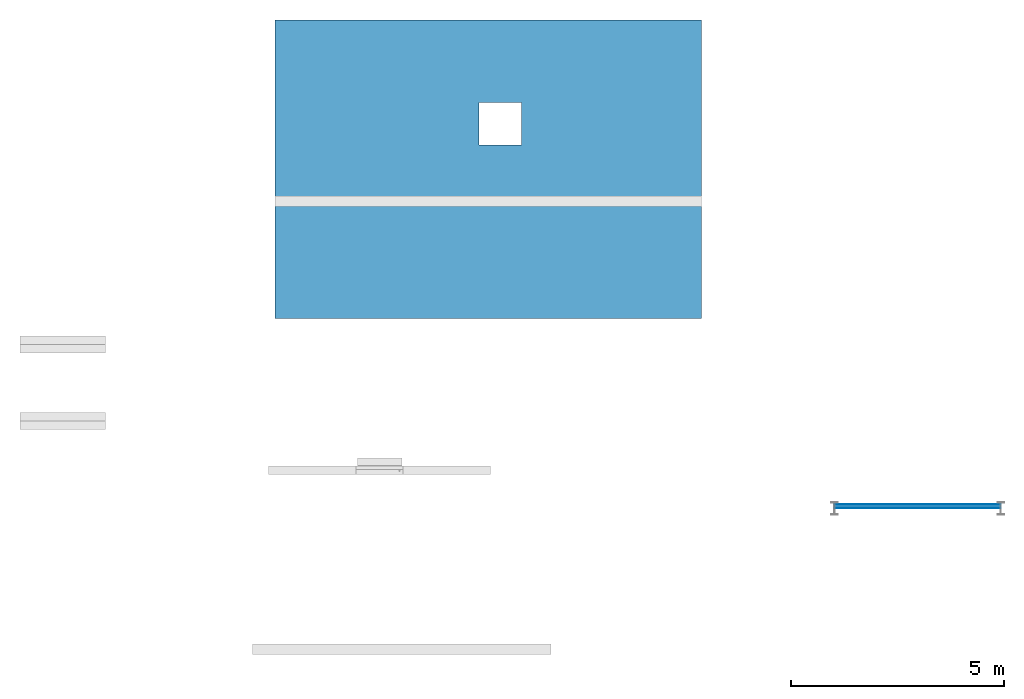
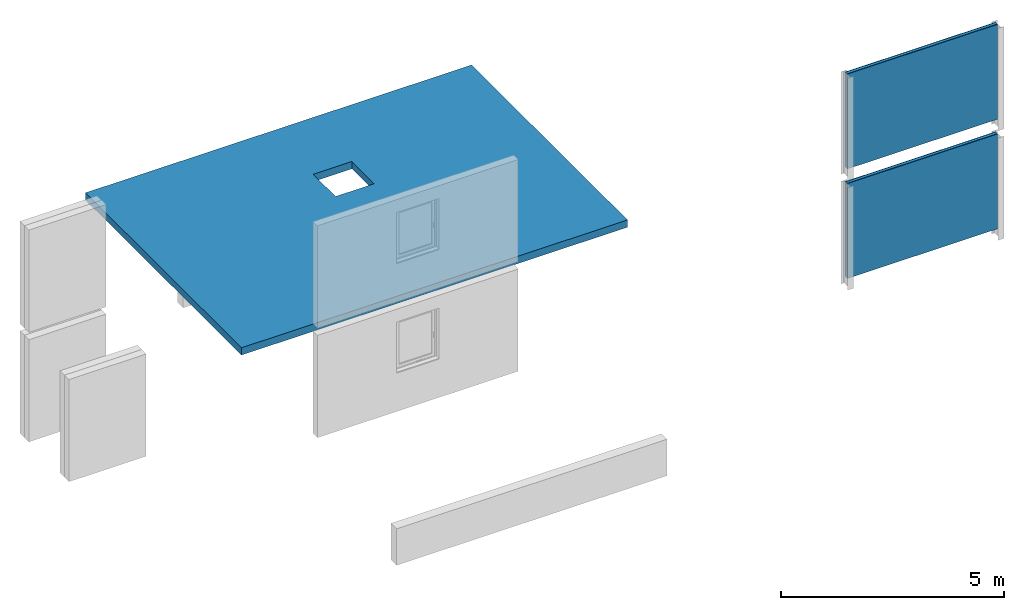
# Not in any storey, part 2 of 3: 7 building element parts, 3 elements without a shape of their own.
"""IFC4 model written with IfcOpenShell, lengths in metres."""

from ifc_helpers import new_model, entity, si_unit, converted_unit, derived_unit, direction, frame, origin, place, context, subcontext, project, spatial, indexed_curve, outline, extrude, material, type_object, element, aggregate, save


model = new_model("IFC4")

# Units and contexts
model_context = context("Model", 3, precision=1e-05, world=origin(), true_north=direction((6.123031769111886e-17, 1.0)))
body_context = subcontext(model_context, "Body", "Model", "MODEL_VIEW")
ifc_project = project(units=[si_unit("LENGTHUNIT", "METRE"), si_unit("AREAUNIT", "SQUARE_METRE"), si_unit("VOLUMEUNIT", "CUBIC_METRE"), converted_unit("PLANEANGLEUNIT", "DEGREE", entity("IfcRatioMeasure", 0.017453292519943278), si_unit("PLANEANGLEUNIT", "RADIAN"), dimensions=[0, 0, 0, 0, 0, 0, 0]), si_unit("MASSUNIT", "GRAM", prefix="KILO"), derived_unit("MASSDENSITYUNIT", [(si_unit("MASSUNIT", "GRAM", prefix="KILO"), 1), (si_unit("LENGTHUNIT", "METRE"), -3)]), derived_unit("IONCONCENTRATIONUNIT", [(si_unit("MASSUNIT", "GRAM", prefix="KILO"), 1), (si_unit("LENGTHUNIT", "METRE"), -3)]), derived_unit("MOMENTOFINERTIAUNIT", [(si_unit("LENGTHUNIT", "METRE"), 4)]), si_unit("TIMEUNIT", "SECOND"), si_unit("FREQUENCYUNIT", "HERTZ"), si_unit("THERMODYNAMICTEMPERATUREUNIT", "DEGREE_CELSIUS"), derived_unit("THERMALTRANSMITTANCEUNIT", [(si_unit("MASSUNIT", "GRAM", prefix="KILO"), 1), (si_unit("THERMODYNAMICTEMPERATUREUNIT", "KELVIN"), -1), (si_unit("TIMEUNIT", "SECOND"), -3)]), derived_unit("THERMALCONDUCTANCEUNIT", [(si_unit("MASSUNIT", "GRAM", prefix="KILO"), 1), (si_unit("THERMODYNAMICTEMPERATUREUNIT", "KELVIN"), -1), (si_unit("TIMEUNIT", "SECOND"), -3), (si_unit("LENGTHUNIT", "METRE"), 1)]), derived_unit("VOLUMETRICFLOWRATEUNIT", [(si_unit("LENGTHUNIT", "METRE"), 3), (si_unit("TIMEUNIT", "SECOND"), -1)]), derived_unit("MASSFLOWRATEUNIT", [(si_unit("MASSUNIT", "GRAM", prefix="KILO"), 1), (si_unit("TIMEUNIT", "SECOND"), -1)]), derived_unit("ROTATIONALFREQUENCYUNIT", [(si_unit("TIMEUNIT", "SECOND"), -1)]), si_unit("ELECTRICCURRENTUNIT", "AMPERE"), si_unit("ELECTRICVOLTAGEUNIT", "VOLT"), si_unit("POWERUNIT", "WATT"), si_unit("FORCEUNIT", "NEWTON", prefix="KILO"), si_unit("ILLUMINANCEUNIT", "LUX"), si_unit("LUMINOUSFLUXUNIT", "LUMEN"), si_unit("LUMINOUSINTENSITYUNIT", "CANDELA"), derived_unit("USERDEFINED", [(si_unit("MASSUNIT", "GRAM", prefix="KILO"), -1), (si_unit("LENGTHUNIT", "METRE"), -2), (si_unit("TIMEUNIT", "SECOND"), 3), (si_unit("LUMINOUSFLUXUNIT", "LUMEN"), 1)]), derived_unit("USERDEFINED", [(si_unit("MASSUNIT", "GRAM", prefix="KILO"), 1), (si_unit("TIMEUNIT", "SECOND"), -3), (si_unit("LENGTHUNIT", "METRE"), 3), (si_unit("ELECTRICCURRENTUNIT", "AMPERE"), -2)]), derived_unit("SOUNDPOWERUNIT", [(si_unit("MASSUNIT", "GRAM", prefix="KILO"), 1), (si_unit("TIMEUNIT", "SECOND"), -3), (si_unit("LENGTHUNIT", "METRE"), 2)]), derived_unit("SOUNDPRESSUREUNIT", [(si_unit("MASSUNIT", "GRAM", prefix="KILO"), 1), (si_unit("LENGTHUNIT", "METRE"), -1), (si_unit("TIMEUNIT", "SECOND"), -2)]), derived_unit("LINEARVELOCITYUNIT", [(si_unit("LENGTHUNIT", "METRE"), 1), (si_unit("TIMEUNIT", "SECOND"), -1)]), si_unit("PRESSUREUNIT", "PASCAL"), derived_unit("USERDEFINED", [(si_unit("MASSUNIT", "GRAM", prefix="KILO"), 1), (si_unit("LENGTHUNIT", "METRE"), -2), (si_unit("TIMEUNIT", "SECOND"), -2)]), derived_unit("LINEARFORCEUNIT", [(si_unit("MASSUNIT", "GRAM", prefix="KILO"), 1), (si_unit("TIMEUNIT", "SECOND"), -2)]), derived_unit("PLANARFORCEUNIT", [(si_unit("MASSUNIT", "GRAM", prefix="KILO"), 1), (si_unit("LENGTHUNIT", "METRE"), -1), (si_unit("TIMEUNIT", "SECOND"), -2)]), derived_unit("SPECIFICHEATCAPACITYUNIT", [(si_unit("THERMODYNAMICTEMPERATUREUNIT", "KELVIN"), -1), (si_unit("LENGTHUNIT", "METRE"), 2), (si_unit("TIMEUNIT", "SECOND"), -2)]), derived_unit("HEATINGVALUEUNIT", [(si_unit("LENGTHUNIT", "METRE"), 2), (si_unit("TIMEUNIT", "SECOND"), -2)]), derived_unit("VAPORPERMEABILITYUNIT", [(si_unit("LENGTHUNIT", "METRE"), -1), (si_unit("TIMEUNIT", "SECOND"), 1)]), derived_unit("DYNAMICVISCOSITYUNIT", [(si_unit("MASSUNIT", "GRAM", prefix="KILO"), 1), (si_unit("TIMEUNIT", "SECOND"), -1), (si_unit("LENGTHUNIT", "METRE"), -1)]), derived_unit("THERMALEXPANSIONCOEFFICIENTUNIT", [(si_unit("THERMODYNAMICTEMPERATUREUNIT", "KELVIN"), -1)]), derived_unit("MODULUSOFELASTICITYUNIT", [(si_unit("MASSUNIT", "GRAM", prefix="KILO"), 1), (si_unit("LENGTHUNIT", "METRE"), -1), (si_unit("TIMEUNIT", "SECOND"), -2)]), derived_unit("ISOTHERMALMOISTURECAPACITYUNIT", [(si_unit("LENGTHUNIT", "METRE"), 3), (si_unit("MASSUNIT", "GRAM", prefix="KILO"), -1)]), derived_unit("MOISTUREDIFFUSIVITYUNIT", [(si_unit("TIMEUNIT", "SECOND"), -1), (si_unit("LENGTHUNIT", "METRE"), 2)])], contexts=[model_context])

# Site
site_placement = place(None, origin())
site = spatial("IfcSite", under=ifc_project, at=site_placement, CompositionType="ELEMENT")

# Slab, building element part
slab_type = type_object("IfcSlabType", Name="Geschossdecke:STB 200", PredefinedType="NOTDEFINED")
slab_placement = place(site_placement, origin())
slab = element("IfcSlab", 1, at=slab_placement, inside=site, type_object=slab_type, Name="Geschossdecke:STB 200", ObjectType="Geschossdecke:STB 200", PredefinedType="NOTDEFINED")
ifc_material_1 = material(Name="Ortbeton - bewehrt", Category="Generisch")
building_element_part_1_placement = place(slab_placement, origin())
building_element_part_1 = element("IfcBuildingElementPart", 2, at=building_element_part_1_placement, material=ifc_material_1, Name="Ortbeton - bewehrt", context=body_context, shape_type="SweptSolid", body=[
    extrude(outline(indexed_curve([(-3.12442591888401, -5.0), (-0.500574081116013, -5.0), (-0.2505740811160113, -5.0), (3.875574081115993, -5.0), (3.875574081115993, 5.0), (-0.2505740811159745, 5.0), (-0.5005740811159783, 5.0), (-3.12442591888401, 5.0), (-3.12442591888401, -5.0)], self_intersect=False), holes=[indexed_curve([(1.946530144596606, -0.785276724406635), (0.9465301445966037, -0.785276724406635), (0.9465301445966037, 0.21472327559336724), (1.946530144596606, 0.21472327559336724), (1.946530144596606, -0.785276724406635)], self_intersect=False)]), frame((17.68019408176987, 17.175777620029596, -0.2), z_axis=(0.0, 0.0, 1.0), x_axis=(0.0, 1.0, 0.0)), (0.0, 0.0, 1.0), 0.2),
])
aggregate(slab, [building_element_part_1])

# Wall, building element parts
wall_type = type_object("IfcWallType", Name="GK 100", PredefinedType="STANDARD")
wall_1_placement = place(site_placement, frame((25.803550000000016, 9.650203538913606, 0.0)))
wall_1 = element("IfcWall", 3, at=wall_1_placement, inside=site, type_object=wall_type, Name="GK 100", ObjectType="GK 100", PredefinedType="NOTDEFINED")
ifc_material_2 = material(Name="Trockenbau - Gipsplatte", Category="Nicht")
building_element_part_2_placement = place(wall_1_placement, origin())
building_element_part_2 = element("IfcBuildingElementPart", 4, at=building_element_part_2_placement, material=ifc_material_2, Name="Trockenbau - Gipsplatte", context=body_context, shape_type="SweptSolid", body=[
    extrude(outline(indexed_curve([(-0.006250000000007242, -1.9482250000000054), (0.006249999999993165, -1.9482250000000012), (0.0062500000000061595, 1.9482250000000012), (-0.006249999999994248, 1.9482250000000012), (-0.006250000000007242, -1.9482250000000054)], self_intersect=False)), frame((1.9482249999999994, -0.043750000000000885, 0.0), z_axis=(0.0, 0.0, 1.0), x_axis=(0.0, -1.0, 0.0)), (0.0, 0.0, 1.0), 2.6),
])
ifc_material_3 = material(Category="Generisch")
building_element_part_3_placement = place(wall_1_placement, origin())
building_element_part_3 = element("IfcBuildingElementPart", 5, at=building_element_part_3_placement, material=ifc_material_3, context=body_context, shape_type="SweptSolid", body=[
    extrude(outline(indexed_curve([(-0.03750000000000663, -1.9482250000000012), (0.03749999999999364, -1.9482250000000054), (0.03750000000000663, 1.9482250000000012), (-0.03749999999999364, 1.9482250000000012), (-0.03750000000000663, -1.9482250000000012)], self_intersect=False)), frame((1.9482249999999992, 0.0, 0.0), z_axis=(0.0, 0.0, 1.0), x_axis=(0.0, -1.0, 0.0)), (0.0, 0.0, 1.0), 2.6),
])
building_element_part_4_placement = place(wall_1_placement, origin())
building_element_part_4 = element("IfcBuildingElementPart", 6, at=building_element_part_4_placement, material=ifc_material_2, Name="Trockenbau - Gipsplatte", context=body_context, shape_type="SweptSolid", body=[
    extrude(outline(indexed_curve([(-0.006250000000007242, -1.9482250000000012), (0.006249999999992082, -1.9482250000000012), (0.006250000000005076, 1.9482250000000012), (-0.006249999999994248, 1.9482250000000012), (-0.006250000000007242, -1.9482250000000012)], self_intersect=False)), frame((1.9482249999999992, 0.04374999999999872, 0.0), z_axis=(0.0, 0.0, 1.0), x_axis=(0.0, -1.0, 0.0)), (0.0, 0.0, 1.0), 2.6),
])
aggregate(wall_1, [building_element_part_2, building_element_part_3, building_element_part_4])

wall_2_placement = place(site_placement, frame((25.803550000000016, 9.650203538913606, 0.0)))
wall_2 = element("IfcWall", 7, at=wall_2_placement, inside=site, type_object=wall_type, Name="GK 100", ObjectType="GK 100", PredefinedType="NOTDEFINED")
building_element_part_5_placement = place(wall_2_placement, origin())
building_element_part_5 = element("IfcBuildingElementPart", 8, at=building_element_part_5_placement, material=ifc_material_2, Name="Trockenbau - Gipsplatte", context=body_context, shape_type="SweptSolid", body=[
    extrude(outline(indexed_curve([(-0.006250000000007242, -1.9482250000000054), (0.006249999999993165, -1.9482250000000012), (0.0062500000000061595, 1.9482250000000012), (-0.006249999999994248, 1.9482250000000012), (-0.006250000000007242, -1.9482250000000054)], self_intersect=False)), frame((1.9482249999999994, -0.043750000000000885, 3.0), z_axis=(0.0, 0.0, 1.0), x_axis=(0.0, -1.0, 0.0)), (0.0, 0.0, 1.0), 2.6000000000000005),
])
building_element_part_6_placement = place(wall_2_placement, origin())
building_element_part_6 = element("IfcBuildingElementPart", 9, at=building_element_part_6_placement, material=ifc_material_3, context=body_context, shape_type="SweptSolid", body=[
    extrude(outline(indexed_curve([(-0.03750000000000663, -1.9482250000000012), (0.03749999999999364, -1.9482250000000054), (0.03750000000000663, 1.9482250000000012), (-0.03749999999999364, 1.9482250000000012), (-0.03750000000000663, -1.9482250000000012)], self_intersect=False)), frame((1.9482249999999992, 0.0, 3.0), z_axis=(0.0, 0.0, 1.0), x_axis=(0.0, -1.0, 0.0)), (0.0, 0.0, 1.0), 2.6000000000000005),
])
building_element_part_7_placement = place(wall_2_placement, origin())
building_element_part_7 = element("IfcBuildingElementPart", 10, at=building_element_part_7_placement, material=ifc_material_2, Name="Trockenbau - Gipsplatte", context=body_context, shape_type="SweptSolid", body=[
    extrude(outline(indexed_curve([(-0.006250000000007242, -1.9482250000000012), (0.006249999999992082, -1.9482250000000012), (0.006250000000005076, 1.9482250000000012), (-0.006249999999994248, 1.9482250000000012), (-0.006250000000007242, -1.9482250000000012)], self_intersect=False)), frame((1.9482249999999992, 0.04374999999999872, 3.0), z_axis=(0.0, 0.0, 1.0), x_axis=(0.0, -1.0, 0.0)), (0.0, 0.0, 1.0), 2.6),
])
aggregate(wall_2, [building_element_part_5, building_element_part_6, building_element_part_7])

save(model, "model.ifc")
